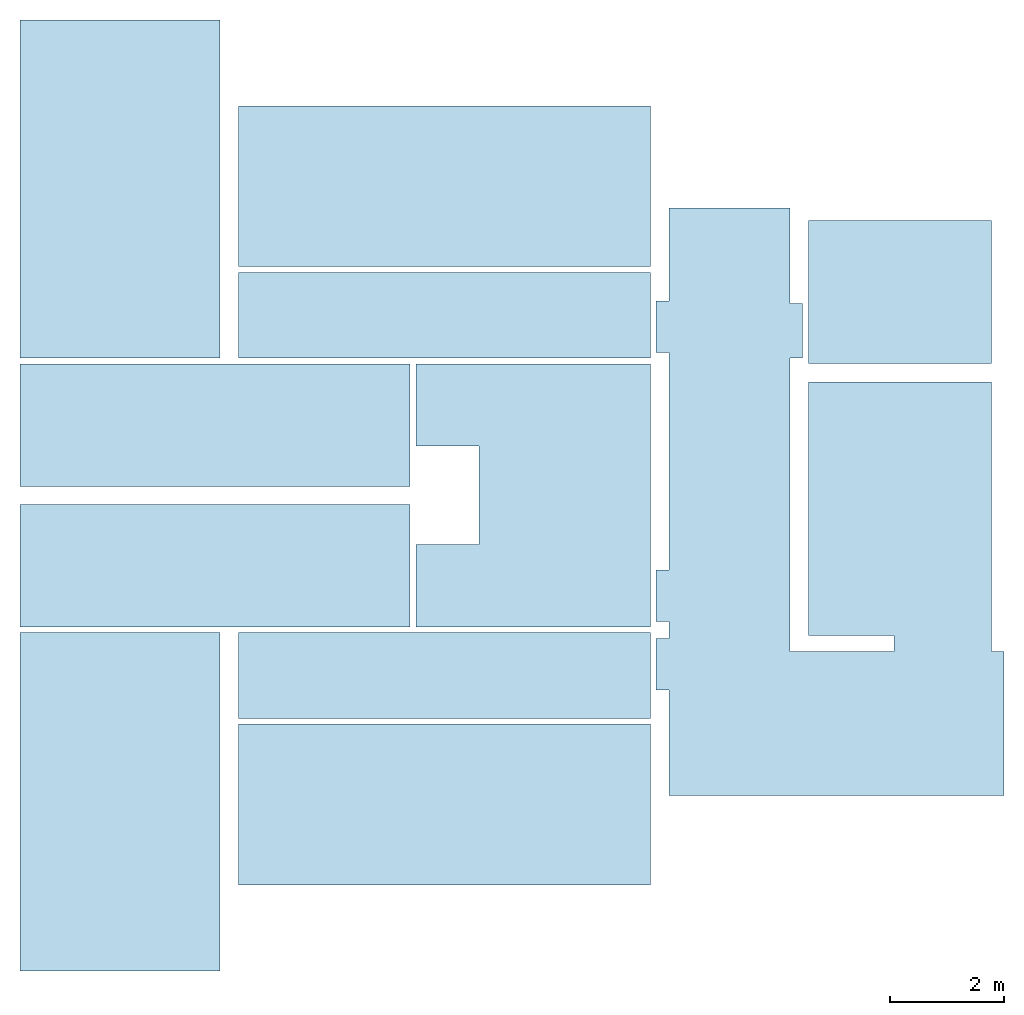
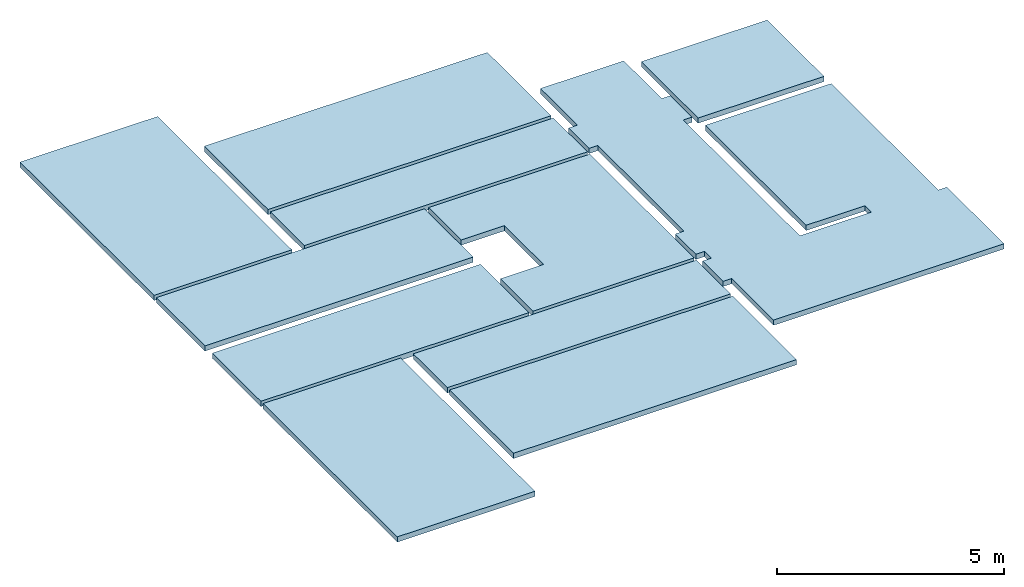
# One storey: 11 slabs.
"""IFC2X3 building model written with IfcOpenShell, lengths in millimetres."""

from ifc_helpers import new_model, entity, si_unit, converted_unit, derived_unit, direction, frame, frame_2d, origin, place, context, subcontext, project, spatial, polyline, rectangle, outline, extrude, material, layer, layer_set, layer_usage, type_object, element, save


model = new_model("IFC2X3")

# Units and contexts
model_context = context("Model", 3, precision=0.01, world=origin(), true_north=direction((6.12303176911189e-17, 1.0)))
body_context = subcontext(model_context, "Body", "Model", "MODEL_VIEW")
ifc_project = project(units=[si_unit("LENGTHUNIT", "METRE", prefix="MILLI"), si_unit("AREAUNIT", "SQUARE_METRE"), si_unit("VOLUMEUNIT", "CUBIC_METRE"), converted_unit("PLANEANGLEUNIT", "DEGREE", entity("IfcRatioMeasure", 0.0174532925199433), si_unit("PLANEANGLEUNIT", "RADIAN"), dimensions=[0, 0, 0, 0, 0, 0, 0]), si_unit("MASSUNIT", "GRAM", prefix="KILO"), derived_unit("MASSDENSITYUNIT", [(si_unit("MASSUNIT", "GRAM", prefix="KILO"), 1), (si_unit("LENGTHUNIT", "METRE"), -3)]), si_unit("TIMEUNIT", "SECOND"), si_unit("FREQUENCYUNIT", "HERTZ"), si_unit("THERMODYNAMICTEMPERATUREUNIT", "DEGREE_CELSIUS"), derived_unit("THERMALTRANSMITTANCEUNIT", [(si_unit("MASSUNIT", "GRAM", prefix="KILO"), 1), (si_unit("THERMODYNAMICTEMPERATUREUNIT", "KELVIN"), -1), (si_unit("TIMEUNIT", "SECOND"), -3)]), derived_unit("VOLUMETRICFLOWRATEUNIT", [(si_unit("LENGTHUNIT", "METRE"), 3), (si_unit("TIMEUNIT", "SECOND"), -1)]), si_unit("ELECTRICCURRENTUNIT", "AMPERE"), si_unit("ELECTRICVOLTAGEUNIT", "VOLT"), si_unit("POWERUNIT", "WATT"), si_unit("FORCEUNIT", "NEWTON", prefix="KILO"), si_unit("ILLUMINANCEUNIT", "LUX"), si_unit("LUMINOUSFLUXUNIT", "LUMEN"), si_unit("LUMINOUSINTENSITYUNIT", "CANDELA"), derived_unit("USERDEFINED", [(si_unit("MASSUNIT", "GRAM", prefix="KILO"), -1), (si_unit("LENGTHUNIT", "METRE"), -2), (si_unit("TIMEUNIT", "SECOND"), 3), (si_unit("LUMINOUSFLUXUNIT", "LUMEN"), 1)]), derived_unit("LINEARVELOCITYUNIT", [(si_unit("LENGTHUNIT", "METRE"), 1), (si_unit("TIMEUNIT", "SECOND"), -1)]), si_unit("PRESSUREUNIT", "PASCAL"), derived_unit("USERDEFINED", [(si_unit("LENGTHUNIT", "METRE"), -2), (si_unit("MASSUNIT", "GRAM", prefix="KILO"), 1), (si_unit("TIMEUNIT", "SECOND"), -2)])], contexts=[model_context])

# Site, building, storey
site_placement = place(None, origin())
site = spatial("IfcSite", under=ifc_project, at=site_placement, CompositionType="ELEMENT")
building_placement = place(site_placement, origin())
building = spatial("IfcBuilding", under=site, at=building_placement, CompositionType="ELEMENT")
storey_placement = place(building_placement, origin())
storey = spatial("IfcBuildingStorey", under=building, at=storey_placement, Name="00 Ground level", CompositionType="ELEMENT", Elevation=0.0)

# Slabs
ifc_material_1 = material(Name="07")
ifc_layer_1 = layer(ifc_material_1, 15.0)
ifc_material_2 = material(Name="06")
ifc_layer_2 = layer(ifc_material_2, 5.0)
ifc_material_3 = material(Name="02_C40/55")
ifc_layer_3 = layer(ifc_material_3, 60.0)
ifc_material_4 = material()
ifc_layer_4 = layer(ifc_material_4, 60.0)
ifc_layer_set = layer_set([ifc_layer_1, ifc_layer_2, ifc_layer_3, ifc_layer_4], Name="Floor")
ifc_layer_usage_1 = layer_usage(ifc_layer_set, "AXIS3", "POSITIVE", 0.0)
slab_type_1 = type_object("IfcSlabType", Name="Floor", PredefinedType="FLOOR", material=ifc_layer_set)
slab_1_placement = place(storey_placement, origin())
element("IfcSlab", 1, at=slab_1_placement, inside=storey, type_object=slab_type_1, material=ifc_layer_usage_1, Name="Floor", ObjectType="Floor", PredefinedType="FLOOR", context=body_context, shape_type="SweptSolid", body=[
    extrude(outline(polyline([(-3122.73736831066, -1920.0), (-2222.73736831065, -1920.0), (-2222.73736831065, -1700.0), (-1922.73736831065, -1700.0), (-1922.73736831065, -1920.0), (-1022.73736831065, -1920.0), (-1022.73736831065, -1700.0), (2777.26263168936, -1700.0), (2777.26263168936, -1920.0), (3677.26263168937, -1920.0), (3677.26263168937, -1700.0), (5302.67802623296, -1700.0), (5302.67802623296, 420.0), (3632.67802623295, 420.0), (3632.67802623295, 640.0), (2682.67802623295, 640.0), (2682.67802623295, 420.0), (-2452.32197376702, 420.0), (-2452.32197376702, 2240.0), (-2172.32197376703, 2240.0), (-2172.32197376702, 740.0), (2262.67802623295, 740.0), (2262.67802623295, 3940.0), (-2452.32197376702, 3940.0), (-2452.32197376702, 4160.0), (-4967.32197376701, 4160.0), (-4967.32197376701, -1700.0), (-3122.73736831066, -1700.0), (-3122.73736831066, -1920.0)])), frame((30523.4900708515, -69108.5022168293, 0.0), z_axis=(0.0, 0.0, -1.0), x_axis=(0.0, 1.0, 0.0)), (0.0, 0.0, 1.0), 140.0),
])
ifc_layer_usage_2 = layer_usage(ifc_layer_set, "AXIS3", "POSITIVE", 0.0)
slab_type_2 = type_object("IfcSlabType", Name="Floor", PredefinedType="FLOOR", material=ifc_layer_set)
slab_2_placement = place(storey_placement, origin())
element("IfcSlab", 2, at=slab_2_placement, inside=storey, type_object=slab_type_2, material=ifc_layer_usage_2, Name="Floor", ObjectType="Floor", PredefinedType="FLOOR", context=body_context, shape_type="SweptSolid", body=[
    extrude(rectangle(XDim=2500.0, YDim=3199.99999999997, at=frame_2d((0.0, 2.1600499167107e-12), x_axis=(1.0, 0.0))), frame((32863.4900708518, -65275.8241905964, 0.0), z_axis=(0.0, 0.0, -1.0), x_axis=(0.0, 1.0, 0.0)), (0.0, 0.0, 1.0), 140.0),
])
ifc_layer_usage_3 = layer_usage(ifc_layer_set, "AXIS3", "POSITIVE", 0.0)
slab_type_3 = type_object("IfcSlabType", Name="Floor", PredefinedType="FLOOR")
slab_3_placement = place(storey_placement, frame((17483.4900708517, -77141.2395851399, -140.0)))
element("IfcSlab", 3, at=slab_3_placement, inside=storey, type_object=slab_type_3, material=ifc_layer_usage_3, Name="Floor", ObjectType="Floor", PredefinedType="FLOOR", context=body_context, shape_type="SweptSolid", body=[
    extrude(rectangle(XDim=1500.00000000003, YDim=7199.99999999999, at=frame_2d((-1910.0, -3150.0), x_axis=(0.0, -1.0))), frame((5510.0, 8310.0, 140.0), z_axis=(0.0, 0.0, -1.0), x_axis=(-1.0, 0.0, 0.0)), (0.0, 0.0, 1.0), 140.0),
])
slab_type_4 = type_object("IfcSlabType", Name="Floor", PredefinedType="FLOOR")
slab_4_placement = place(storey_placement, frame((17483.4900708517, -77141.2395851399, -140.0)))
element("IfcSlab", 4, at=slab_4_placement, inside=storey, type_object=slab_type_4, material=ifc_layer_usage_3, Name="Floor:2", ObjectType="Floor", PredefinedType="FLOOR", context=body_context, shape_type="SweptSolid", body=[
    extrude(rectangle(XDim=7199.99999999999, YDim=2809.99999999996, at=frame_2d((-1910.0, -5405.0), x_axis=(-1.0, 0.0))), frame((5510.0, 8310.0, 140.0), z_axis=(0.0, 0.0, -1.0), x_axis=(-1.0, 0.0, 0.0)), (0.0, 0.0, 1.0), 140.0),
])
slab_type_5 = type_object("IfcSlabType", Name="Floor", PredefinedType="FLOOR")
slab_5_placement = place(storey_placement, frame((17483.4900708517, -77141.2395851399, -140.0)))
element("IfcSlab", 5, at=slab_5_placement, inside=storey, type_object=slab_type_5, material=ifc_layer_usage_3, Name="Floor:3", ObjectType="Floor", PredefinedType="FLOOR", context=body_context, shape_type="SweptSolid", body=[
    extrude(rectangle(XDim=5909.99999999997, YDim=3500.00000000002, at=frame_2d((3760.0, -5355.0), x_axis=(0.0, -1.0))), frame((5510.0, 8310.0, 140.0), z_axis=(0.0, 0.0, -1.0), x_axis=(-1.0, 0.0, 0.0)), (0.0, 0.0, 1.0), 140.0),
])
slab_type_6 = type_object("IfcSlabType", Name="Floor", PredefinedType="FLOOR")
slab_6_placement = place(storey_placement, frame((17483.4900708517, -77141.2395851399, -140.0)))
element("IfcSlab", 6, at=slab_6_placement, inside=storey, type_object=slab_type_6, material=ifc_layer_usage_3, Name="Floor:4", ObjectType="Floor", PredefinedType="FLOOR", context=body_context, shape_type="SweptSolid", body=[
    extrude(rectangle(XDim=2140.00000000002, YDim=6820.00000000002, at=frame_2d((2100.0, -1230.0), x_axis=(0.0, -1.0))), frame((5510.0, 8310.0, 140.0), z_axis=(0.0, 0.0, -1.0), x_axis=(-1.0, 0.0, 0.0)), (0.0, 0.0, 1.0), 140.0),
])
slab_type_7 = type_object("IfcSlabType", Name="Floor", PredefinedType="FLOOR")
slab_7_placement = place(storey_placement, frame((17483.4900708517, -77141.2395851399, -140.0)))
element("IfcSlab", 7, at=slab_7_placement, inside=storey, type_object=slab_type_7, material=ifc_layer_usage_3, Name="Floor:5", ObjectType="Floor", PredefinedType="FLOOR", context=body_context, shape_type="SweptSolid", body=[
    extrude(outline(polyline([(-1410.0, -2300.0), (-1410.0, -860.0), (-2510.0, -860.0), (-2510.0, 860.0), (-1410.0, 860.0), (-1410.0, 2300.0), (-5510.0, 2300.0), (-5510.0, -2300.0), (-1410.0, -2300.0)])), frame((5510.0, 8310.0, 140.0), z_axis=(0.0, 0.0, -1.0), x_axis=(-1.0, 0.0, 0.0)), (0.0, 0.0, 1.0), 140.0),
])
slab_type_8 = type_object("IfcSlabType", Name="Floor", PredefinedType="FLOOR")
slab_8_placement = place(storey_placement, frame((17483.4900708517, -77141.2395851399, -140.0)))
element("IfcSlab", 8, at=slab_8_placement, inside=storey, type_object=slab_type_8, material=ifc_layer_usage_3, Name="Floor:6", ObjectType="Floor", PredefinedType="FLOOR", context=body_context, shape_type="SweptSolid", body=[
    extrude(rectangle(XDim=7199.99999999999, YDim=1500.00000000004, at=frame_2d((-1910.0, 3150.0), x_axis=(1.0, 0.0))), frame((5510.0, 8310.0, 140.0), z_axis=(0.0, 0.0, -1.0), x_axis=(-1.0, 0.0, 0.0)), (0.0, 0.0, 1.0), 140.0),
])
slab_type_9 = type_object("IfcSlabType", Name="Floor", PredefinedType="FLOOR")
slab_9_placement = place(storey_placement, frame((17483.4900708517, -77141.2395851399, -140.0)))
element("IfcSlab", 9, at=slab_9_placement, inside=storey, type_object=slab_type_9, material=ifc_layer_usage_3, Name="Floor:7", ObjectType="Floor", PredefinedType="FLOOR", context=body_context, shape_type="SweptSolid", body=[
    extrude(rectangle(XDim=2809.99999999995, YDim=7200.0, at=frame_2d((-1910.0, 5405.0), x_axis=(0.0, 1.0))), frame((5510.0, 8310.0, 140.0), z_axis=(0.0, 0.0, -1.0), x_axis=(-1.0, 0.0, 0.0)), (0.0, 0.0, 1.0), 140.0),
])
slab_type_10 = type_object("IfcSlabType", Name="Floor", PredefinedType="FLOOR")
slab_10_placement = place(storey_placement, frame((17483.4900708517, -77141.2395851399, -140.0)))
element("IfcSlab", 10, at=slab_10_placement, inside=storey, type_object=slab_type_10, material=ifc_layer_usage_3, Name="Floor:8", ObjectType="Floor", PredefinedType="FLOOR", context=body_context, shape_type="SweptSolid", body=[
    extrude(rectangle(XDim=3500.0, YDim=5909.99999999999, at=frame_2d((3760.0, 5355.0), x_axis=(1.0, 0.0))), frame((5510.0, 8310.0, 140.0), z_axis=(0.0, 0.0, -1.0), x_axis=(-1.0, 0.0, 0.0)), (0.0, 0.0, 1.0), 140.0),
])
slab_type_11 = type_object("IfcSlabType", Name="Floor", PredefinedType="FLOOR", material=ifc_layer_set)
slab_11_placement = place(storey_placement, frame((17483.4900708517, -77141.2395851399, -140.0)))
element("IfcSlab", 11, at=slab_11_placement, inside=storey, type_object=slab_type_11, material=ifc_layer_usage_3, Name="Floor:9", ObjectType="Floor", PredefinedType="FLOOR", context=body_context, shape_type="SweptSolid", body=[
    extrude(rectangle(XDim=6820.00000000002, YDim=2140.00000000002, at=frame_2d((2100.0, 1230.0), x_axis=(1.0, 0.0))), frame((5510.0, 8310.0, 140.0), z_axis=(0.0, 0.0, -1.0), x_axis=(-1.0, 0.0, 0.0)), (0.0, 0.0, 1.0), 140.0),
])

save(model, "model.ifc")
